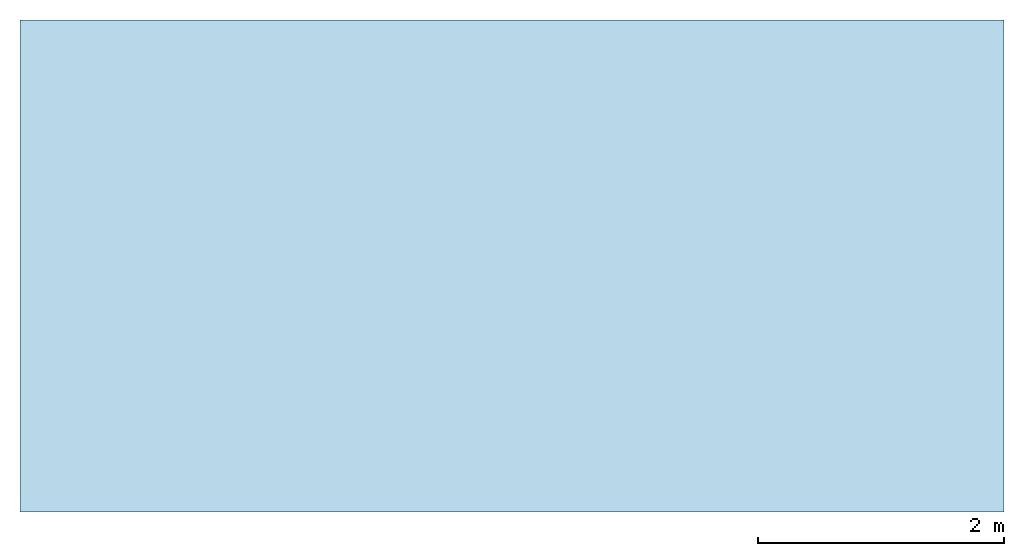
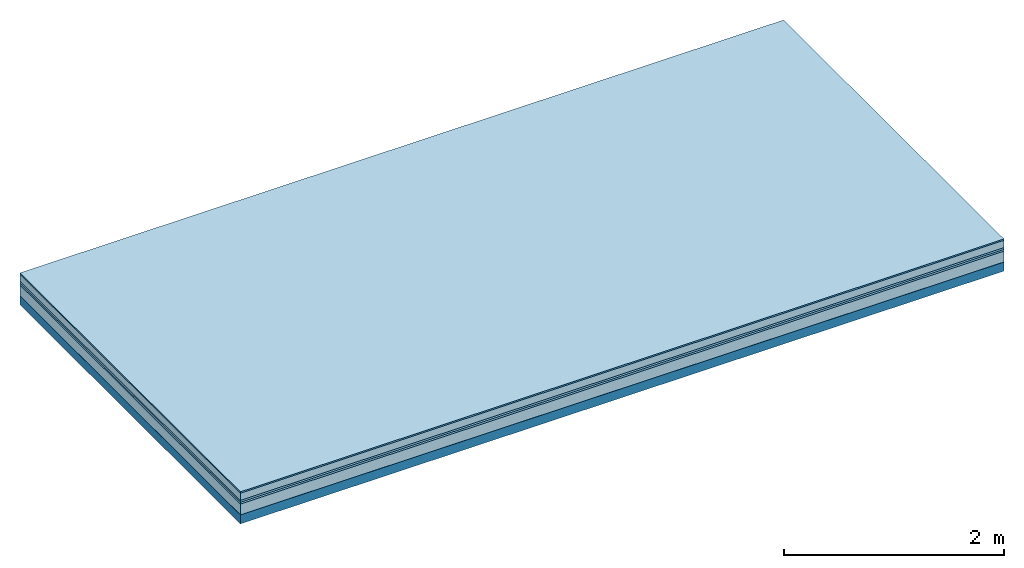
# One storey: 6 plates, 1 member, 1 element without a shape of its own.
"""IFC4 building model written with IfcOpenShell, lengths in metres."""

from ifc_helpers import new_model, si_unit, derived_unit, direction, frame, frame_2d, origin, origin_with_axes, place, context, project, spatial, rectangle, extrude, material, layer, layer_set, type_object, element, aggregate, save


model = new_model("IFC4")

# Units and contexts
plan_context = context("Plan", 3, precision=1e-05, world=origin(), true_north=direction((0.0, 1.0)))
model_context = context("Model", 3, precision=1e-05, world=origin(), true_north=direction((0.0, 1.0)))
ifc_project = project(units=[si_unit("LENGTHUNIT", "METRE"), derived_unit("SOUNDPRESSUREUNIT", [(si_unit("PRESSUREUNIT", "PASCAL", prefix="MICRO"), 0)]), si_unit("ENERGYUNIT", "JOULE", prefix="MEGA"), si_unit("MASSUNIT", "GRAM", prefix="KILO"), derived_unit("THERMALTRANSMITTANCEUNIT", [(si_unit("POWERUNIT", "WATT"), 1), (si_unit("AREAUNIT", "SQUARE_METRE"), -1), (si_unit("THERMODYNAMICTEMPERATUREUNIT", "KELVIN"), -1)]), derived_unit("AREADENSITYUNIT", [(si_unit("MASSUNIT", "GRAM", prefix="KILO"), 1), (si_unit("AREAUNIT", "SQUARE_METRE"), -1)]), derived_unit("USERDEFINED", [(si_unit("ENERGYUNIT", "JOULE", prefix="MEGA"), 1), (si_unit("AREAUNIT", "SQUARE_METRE"), -1)])], contexts=[plan_context, model_context])

# Site, building, storey
site = spatial("IfcSite", under=ifc_project)
building_placement = place(None, origin())
building = spatial("IfcBuilding", under=site, at=building_placement)
storey_placement = place(building_placement, origin())
storey = spatial("IfcBuildingStorey", under=building, at=storey_placement)

# Slab, member, plates
ifc_material_1 = material(Category="11.013")
ifc_layer_1 = layer(ifc_material_1, 0.015, Name="Flooring")
ifc_material_2 = material(Name="Cement screed", Category="04.006")
ifc_layer_2 = layer(ifc_material_2, 0.08, Name="On-material")
ifc_material_3 = material(Name="Wood fiber generic product", Category="10.009")
ifc_layer_3 = layer(ifc_material_3, 0.02, Name="Impact sound insulation")
ifc_material_4 = material()
ifc_layer_4 = layer(ifc_material_4, 0.02, Name="Additional insulation")
ifc_material_5 = material(Category="03.011")
ifc_layer_5 = layer(ifc_material_5, 0.12, Name="on Supporting structure")
ifc_material_6 = material(Name="protection", Category="09.007")
ifc_layer_6 = layer(ifc_material_6, 0.0005, Name="Sub-floor")
ifc_material_7 = material(Name="no composite action")
ifc_layer_7 = layer(ifc_material_7, 0.0, Name="Bond")
ifc_layer_8 = layer(None, 0.1, Name="Supporting structure")
ifc_layer_set = layer_set([ifc_layer_1, ifc_layer_2, ifc_layer_3, ifc_layer_4, ifc_layer_5, ifc_layer_6, ifc_layer_7, ifc_layer_8])
slab_type = type_object("IfcSlabType", Name="A2077", PredefinedType="NOTDEFINED", material=ifc_layer_set)
slab_placement = place(None, frame((0.0, 0.0, 0.0), z_axis=(0.0, 0.0, -1.0), x_axis=(1.0, 0.0, 0.0)))
slab = element("IfcSlab", 1, at=slab_placement, inside=storey, type_object=slab_type, material=ifc_layer_set, Name="Slab #1")
ifc_material_8 = material(Name="Solid timber panel")
member_placement = place(slab_placement, origin())
member = element("IfcMember", 2, at=member_placement, material=ifc_material_8, Name="Supporting structure", context=plan_context, shape_type="SweptSolid", body=[
    extrude(rectangle(XDim=1.0, YDim=0.1, at=frame_2d((0.5, 0.05), x_axis=(1.0, 0.0))), frame((0.0, 4.0, 0.2555), z_axis=(0.0, -1.0, 0.0), x_axis=(1.0, 0.0, 0.0)), (0.0, 0.0, 1.0), 4.0),
    extrude(rectangle(XDim=1.0, YDim=0.1, at=frame_2d((0.5, 0.05), x_axis=(1.0, 0.0))), frame((1.0, 4.0, 0.2555), z_axis=(0.0, -1.0, 0.0), x_axis=(1.0, 0.0, 0.0)), (0.0, 0.0, 1.0), 4.0),
    extrude(rectangle(XDim=1.0, YDim=0.1, at=frame_2d((0.5, 0.05), x_axis=(1.0, 0.0))), frame((2.0, 4.0, 0.2555), z_axis=(0.0, -1.0, 0.0), x_axis=(1.0, 0.0, 0.0)), (0.0, 0.0, 1.0), 4.0),
    extrude(rectangle(XDim=1.0, YDim=0.1, at=frame_2d((0.5, 0.05), x_axis=(1.0, 0.0))), frame((3.0, 4.0, 0.2555), z_axis=(0.0, -1.0, 0.0), x_axis=(1.0, 0.0, 0.0)), (0.0, 0.0, 1.0), 4.0),
    extrude(rectangle(XDim=1.0, YDim=0.1, at=frame_2d((0.5, 0.05), x_axis=(1.0, 0.0))), frame((4.0, 4.0, 0.2555), z_axis=(0.0, -1.0, 0.0), x_axis=(1.0, 0.0, 0.0)), (0.0, 0.0, 1.0), 4.0),
    extrude(rectangle(XDim=1.0, YDim=0.1, at=frame_2d((0.5, 0.05), x_axis=(1.0, 0.0))), frame((5.0, 4.0, 0.2555), z_axis=(0.0, -1.0, 0.0), x_axis=(1.0, 0.0, 0.0)), (0.0, 0.0, 1.0), 4.0),
    extrude(rectangle(XDim=1.0, YDim=0.1, at=frame_2d((0.5, 0.05), x_axis=(1.0, 0.0))), frame((6.0, 4.0, 0.2555), z_axis=(0.0, -1.0, 0.0), x_axis=(1.0, 0.0, 0.0)), (0.0, 0.0, 1.0), 4.0),
    extrude(rectangle(XDim=1.0, YDim=0.1, at=frame_2d((0.5, 0.05), x_axis=(1.0, 0.0))), frame((7.0, 4.0, 0.2555), z_axis=(0.0, -1.0, 0.0), x_axis=(1.0, 0.0, 0.0)), (0.0, 0.0, 1.0), 4.0),
])
plate_1_placement = place(slab_placement, origin())
plate_1 = element("IfcPlate", 3, at=plate_1_placement, material=ifc_material_1, Name="Flooring", context=plan_context, shape_type="SweptSolid", body=[
    extrude(rectangle(XDim=8.0, YDim=4.0, at=frame_2d((4.0, 2.0), x_axis=(1.0, 0.0))), origin_with_axes(), (0.0, 0.0, 1.0), 0.015),
])
plate_2_placement = place(slab_placement, origin())
plate_2 = element("IfcPlate", 4, at=plate_2_placement, material=ifc_material_2, Name="On-material", context=plan_context, shape_type="SweptSolid", body=[
    extrude(rectangle(XDim=8.0, YDim=4.0, at=frame_2d((4.0, 2.0), x_axis=(1.0, 0.0))), frame((0.0, 0.0, 0.015), z_axis=(0.0, 0.0, 1.0), x_axis=(1.0, 0.0, 0.0)), (0.0, 0.0, 1.0), 0.08),
])
plate_3_placement = place(slab_placement, origin())
plate_3 = element("IfcPlate", 5, at=plate_3_placement, material=ifc_material_3, Name="Impact sound insulation", context=plan_context, shape_type="SweptSolid", body=[
    extrude(rectangle(XDim=8.0, YDim=4.0, at=frame_2d((4.0, 2.0), x_axis=(1.0, 0.0))), frame((0.0, 0.0, 0.095), z_axis=(0.0, 0.0, 1.0), x_axis=(1.0, 0.0, 0.0)), (0.0, 0.0, 1.0), 0.02),
])
plate_4_placement = place(slab_placement, origin())
plate_4 = element("IfcPlate", 6, at=plate_4_placement, material=ifc_material_4, Name="Additional insulation", context=plan_context, shape_type="SweptSolid", body=[
    extrude(rectangle(XDim=8.0, YDim=4.0, at=frame_2d((4.0, 2.0), x_axis=(1.0, 0.0))), frame((0.0, 0.0, 0.115), z_axis=(0.0, 0.0, 1.0), x_axis=(1.0, 0.0, 0.0)), (0.0, 0.0, 1.0), 0.02),
])
plate_5_placement = place(slab_placement, origin())
plate_5 = element("IfcPlate", 7, at=plate_5_placement, material=ifc_material_5, Name="on Supporting structure", context=plan_context, shape_type="SweptSolid", body=[
    extrude(rectangle(XDim=8.0, YDim=4.0, at=frame_2d((4.0, 2.0), x_axis=(1.0, 0.0))), frame((0.0, 0.0, 0.135), z_axis=(0.0, 0.0, 1.0), x_axis=(1.0, 0.0, 0.0)), (0.0, 0.0, 1.0), 0.12),
])
plate_6_placement = place(slab_placement, origin())
plate_6 = element("IfcPlate", 8, at=plate_6_placement, material=ifc_material_6, Name="Sub-floor", context=plan_context, shape_type="SweptSolid", body=[
    extrude(rectangle(XDim=8.0, YDim=4.0, at=frame_2d((4.0, 2.0), x_axis=(1.0, 0.0))), frame((0.0, 0.0, 0.255), z_axis=(0.0, 0.0, 1.0), x_axis=(1.0, 0.0, 0.0)), (0.0, 0.0, 1.0), 0.0005),
])
aggregate(slab, [plate_1, plate_2, plate_3, plate_4, plate_5, plate_6, member])

save(model, "model.ifc")
